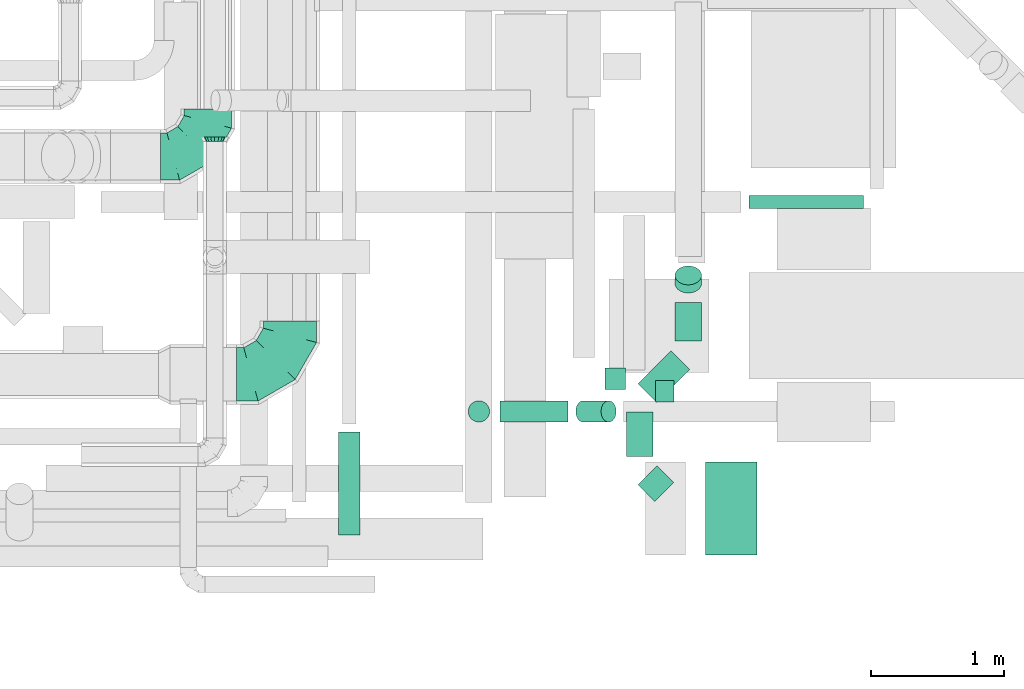
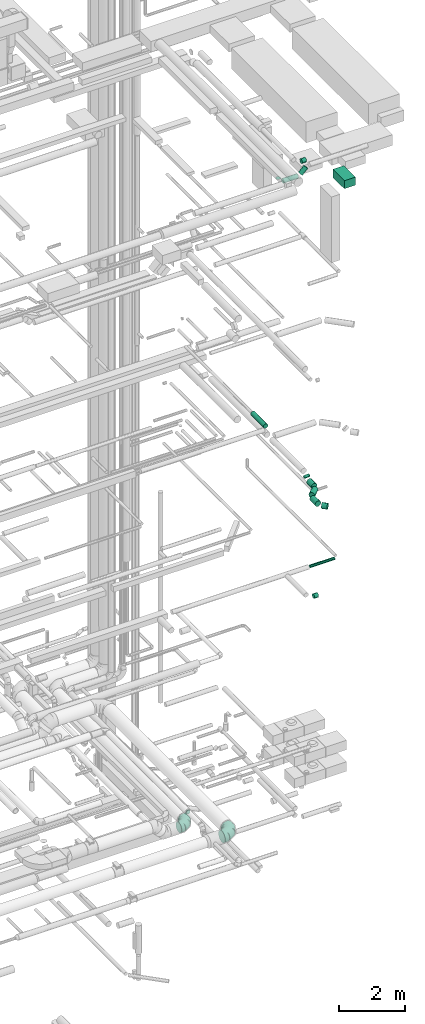
# One storey, part 212 of 337: 13 flow segments, 3 flow fittings.
"""IFC2X3 building model written with IfcOpenShell, lengths in millimetres."""

from ifc_helpers import new_model, entity, si_unit, converted_unit, derived_unit, direction, frame, origin, origin_2d_with_axis, place, context, subcontext, project, spatial, rectangle, circle, extrude, faceted_brep, source, transform, mapped, material, type_object, type_shapes, element, save


model = new_model("IFC2X3")

# Units and contexts
model_context = context("Model", 3, precision=0.01, world=origin(), true_north=direction((6.12303176911189e-17, 1.0)))
body_context = subcontext(model_context, "Body", "Model", "MODEL_VIEW")
ifc_project = project(units=[si_unit("LENGTHUNIT", "METRE", prefix="MILLI"), si_unit("AREAUNIT", "SQUARE_METRE"), si_unit("VOLUMEUNIT", "CUBIC_METRE"), converted_unit("PLANEANGLEUNIT", "DEGREE", entity("IfcRatioMeasure", 0.0174532925199433), si_unit("PLANEANGLEUNIT", "RADIAN"), dimensions=[0, 0, 0, 0, 0, 0, 0]), si_unit("MASSUNIT", "GRAM", prefix="KILO"), derived_unit("MASSDENSITYUNIT", [(si_unit("MASSUNIT", "GRAM", prefix="KILO"), 1), (si_unit("LENGTHUNIT", "METRE"), -3)]), derived_unit("MOMENTOFINERTIAUNIT", [(si_unit("LENGTHUNIT", "METRE"), 4)]), si_unit("TIMEUNIT", "SECOND"), si_unit("FREQUENCYUNIT", "HERTZ"), si_unit("THERMODYNAMICTEMPERATUREUNIT", "DEGREE_CELSIUS"), derived_unit("THERMALTRANSMITTANCEUNIT", [(si_unit("MASSUNIT", "GRAM", prefix="KILO"), 1), (si_unit("THERMODYNAMICTEMPERATUREUNIT", "KELVIN"), -1), (si_unit("TIMEUNIT", "SECOND"), -3)]), derived_unit("VOLUMETRICFLOWRATEUNIT", [(si_unit("LENGTHUNIT", "METRE"), 3), (si_unit("TIMEUNIT", "SECOND"), -1)]), derived_unit("MASSFLOWRATEUNIT", [(si_unit("MASSUNIT", "GRAM", prefix="KILO"), 1), (si_unit("TIMEUNIT", "SECOND"), -1)]), derived_unit("ROTATIONALFREQUENCYUNIT", [(si_unit("TIMEUNIT", "SECOND"), -1)]), si_unit("ELECTRICCURRENTUNIT", "AMPERE"), si_unit("ELECTRICVOLTAGEUNIT", "VOLT"), si_unit("POWERUNIT", "WATT"), si_unit("FORCEUNIT", "NEWTON", prefix="KILO"), si_unit("ILLUMINANCEUNIT", "LUX"), si_unit("LUMINOUSFLUXUNIT", "LUMEN"), si_unit("LUMINOUSINTENSITYUNIT", "CANDELA"), derived_unit("USERDEFINED", [(si_unit("MASSUNIT", "GRAM", prefix="KILO"), -1), (si_unit("LENGTHUNIT", "METRE"), -2), (si_unit("TIMEUNIT", "SECOND"), 3), (si_unit("LUMINOUSFLUXUNIT", "LUMEN"), 1)]), derived_unit("LINEARVELOCITYUNIT", [(si_unit("LENGTHUNIT", "METRE"), 1), (si_unit("TIMEUNIT", "SECOND"), -1)]), si_unit("PRESSUREUNIT", "PASCAL"), derived_unit("USERDEFINED", [(si_unit("LENGTHUNIT", "METRE"), -2), (si_unit("MASSUNIT", "GRAM", prefix="KILO"), 1), (si_unit("TIMEUNIT", "SECOND"), -2)]), derived_unit("LINEARFORCEUNIT", [(si_unit("MASSUNIT", "GRAM", prefix="KILO"), 1), (si_unit("LENGTHUNIT", "METRE"), 1), (si_unit("TIMEUNIT", "SECOND"), -2), (si_unit("LENGTHUNIT", "METRE"), -1)]), derived_unit("PLANARFORCEUNIT", [(si_unit("MASSUNIT", "GRAM", prefix="KILO"), 1), (si_unit("LENGTHUNIT", "METRE"), 1), (si_unit("TIMEUNIT", "SECOND"), -2), (si_unit("LENGTHUNIT", "METRE"), -2)])], contexts=[model_context])

# Site, building, storey
site_placement = place(None, origin())
site = spatial("IfcSite", under=ifc_project, at=site_placement, CompositionType="ELEMENT")
building_placement = place(site_placement, origin())
building = spatial("IfcBuilding", under=site, at=building_placement, CompositionType="ELEMENT")
storey_placement = place(building_placement, origin())
storey = spatial("IfcBuildingStorey", under=building, at=storey_placement, CompositionType="ELEMENT", Elevation=0.0)

# Flow segments
duct_segment_type_1 = type_object("IfcDuctSegmentType", PredefinedType="NOTDEFINED")
flow_segment_1_placement = place(storey_placement, frame((69418.15, 473.12, 27135.0)))
element("IfcFlowSegment", 1, at=flow_segment_1_placement, inside=storey, type_object=duct_segment_type_1, context=body_context, shape_type="SweptSolid", body=[
    extrude(rectangle(XDim=385.000000000034, YDim=700.0, at=origin_2d_with_axis()), frame((192.5, 350.0, 0.0), z_axis=(0.0, 0.0, 1.0), x_axis=(-1.0, 0.0, 0.0)), (0.0, 0.0, 1.0), 300.000000000001),
])
duct_segment_type_2 = type_object("IfcDuctSegmentType", PredefinedType="NOTDEFINED")
flow_segment_2_placement = place(storey_placement, frame((69741.92, 3071.28, 11348.4)))
element("IfcFlowSegment", 2, at=flow_segment_2_placement, inside=storey, type_object=duct_segment_type_2, context=body_context, shape_type="SweptSolid", body=[
    extrude(circle(Radius=50.0, at=origin_2d_with_axis()), frame((0.0, 51.6, 51.6), z_axis=(1.0, 0.0, 0.0), x_axis=(0.0, 1.0, 0.0)), (0.0, 0.0, 1.0), 859.999999999995),
])
flow_segment_3_placement = place(storey_placement, frame((69042.0, 1621.28, 11318.4)))
element("IfcFlowSegment", 3, at=flow_segment_3_placement, inside=storey, type_object=duct_segment_type_2, context=body_context, shape_type="SweptSolid", body=[
    extrude(circle(Radius=80.0, at=origin_2d_with_axis()), frame((0.0, 81.6, 81.6), z_axis=(1.0, 0.0, 0.0), x_axis=(0.0, 1.0, 0.0)), (0.0, 0.0, 1.0), 139.999999999986),
])
flow_segment_4_placement = place(storey_placement, frame((69185.94, 2438.64, 15158.27)))
element("IfcFlowSegment", 4, at=flow_segment_4_placement, inside=storey, type_object=duct_segment_type_2, context=body_context, shape_type="SweptSolid", body=[
    extrude(circle(Radius=100.0, at=origin_2d_with_axis()), frame((101.6, 72.31, 72.31), z_axis=(0.0, 0.707106781186546, 0.707106781186549), x_axis=(-1.0, 0.0, 0.0)), (0.0, 0.0, 1.0), 86.0445891531768),
])
flow_segment_5_placement = place(storey_placement, frame((69185.94, 2078.1, 15070.4)))
element("IfcFlowSegment", 5, at=flow_segment_5_placement, inside=storey, type_object=duct_segment_type_2, context=body_context, shape_type="SweptSolid", body=[
    extrude(circle(Radius=100.0, at=origin_2d_with_axis()), frame((101.6, 0.0, 101.6), z_axis=(0.0, 1.0, 0.0), x_axis=(-1.0, 0.0, 0.0)), (0.0, 0.0, 1.0), 291.425357525385),
])
flow_segment_6_placement = place(storey_placement, frame((68909.09, 1616.82, 15070.4)))
element("IfcFlowSegment", 6, at=flow_segment_6_placement, inside=storey, type_object=duct_segment_type_2, context=body_context, shape_type="SweptSolid", body=[
    extrude(circle(Radius=100.0, at=origin_2d_with_axis()), frame((72.31, 72.31, 101.6), z_axis=(0.707106781186577, 0.707106781186519, 0.0), x_axis=(-0.707106781186519, 0.707106781186577, 0.0)), (0.0, 0.0, 1.0), 350.102274594533),
])
flow_segment_7_placement = place(storey_placement, frame((68821.22, 1214.63, 15070.4)))
element("IfcFlowSegment", 7, at=flow_segment_7_placement, inside=storey, type_object=duct_segment_type_2, context=body_context, shape_type="SweptSolid", body=[
    extrude(circle(Radius=100.0, at=origin_2d_with_axis()), frame((101.6, 0.0, 101.6), z_axis=(0.0, 1.0, 0.0), x_axis=(-1.0, 0.0, 0.0)), (0.0, 0.0, 1.0), 333.068919247703),
])
flow_segment_8_placement = place(storey_placement, frame((68908.79, 874.86, 15070.4)))
element("IfcFlowSegment", 8, at=flow_segment_8_placement, inside=storey, type_object=duct_segment_type_2, context=body_context, shape_type="SweptSolid", body=[
    extrude(circle(Radius=100.0, at=origin_2d_with_axis()), frame((197.88, 72.0, 101.6), z_axis=(-0.704072207353623, 0.710128387569598, 0.0), x_axis=(-0.710128387569598, -0.704072207353623, 0.0)), (0.0, 0.0, 1.0), 177.920841126035),
])
flow_segment_9_placement = place(storey_placement, frame((66662.51, 623.31, 19093.4)))
element("IfcFlowSegment", 9, at=flow_segment_9_placement, inside=storey, type_object=duct_segment_type_2, context=body_context, shape_type="SweptSolid", body=[
    extrude(circle(Radius=80.0, at=origin_2d_with_axis()), frame((81.6, 0.0, 81.6), z_axis=(0.0, 1.0, 0.0), x_axis=(1.0, 0.0, 0.0)), (0.0, 0.0, 1.0), 775.000000000049),
])
flow_segment_10_placement = place(storey_placement, frame((68663.02, 1715.81, 27543.4)))
element("IfcFlowSegment", 10, at=flow_segment_10_placement, inside=storey, type_object=duct_segment_type_2, context=body_context, shape_type="SweptSolid", body=[
    extrude(circle(Radius=80.0, at=origin_2d_with_axis()), frame((0.0, 81.6, 81.6), z_axis=(1.0, 0.0, 0.0), x_axis=(0.0, -1.0, 0.0)), (0.0, 0.0, 1.0), 152.499999999983),
])
flow_segment_11_placement = place(storey_placement, frame((68442.02, 1469.8, 27305.29)))
element("IfcFlowSegment", 11, at=flow_segment_11_placement, inside=storey, type_object=duct_segment_type_2, context=body_context, shape_type="SweptSolid", body=[
    extrude(circle(Radius=80.0, at=origin_2d_with_axis()), frame((58.16, 81.6, 58.16), z_axis=(0.707106781186555, 0.0, 0.707106781186541), x_axis=(0.0, 1.0, 0.0)), (0.0, 0.0, 1.0), 268.248557872836),
])
flow_segment_12_placement = place(storey_placement, frame((67876.73, 1469.8, 27235.0)))
element("IfcFlowSegment", 12, at=flow_segment_12_placement, inside=storey, type_object=duct_segment_type_2, context=body_context, shape_type="SweptSolid", body=[
    extrude(circle(Radius=80.0, at=origin_2d_with_axis()), frame((0.0, 81.6, 81.6), z_axis=(1.0, 0.0, 0.0), x_axis=(0.0, 1.0, 0.0)), (0.0, 0.0, 1.0), 510.319625684626),
])
flow_segment_13_placement = place(storey_placement, frame((67635.13, 1469.8, 27476.59)))
element("IfcFlowSegment", 13, at=flow_segment_13_placement, inside=storey, type_object=duct_segment_type_2, context=body_context, shape_type="SweptSolid", body=[
    extrude(circle(Radius=80.0, at=origin_2d_with_axis()), frame((81.6, 81.6, 0.0), z_axis=(0.0, 0.0, 1.0), x_axis=(0.0, -1.0, 0.0)), (0.0, 0.0, 1.0), 3.40620433568134),
])

# Flow fittings
ifc_material = material()
duct_fitting_type_1 = type_object("IfcDuctFittingType", PredefinedType="NOTDEFINED", material=ifc_material)
shared_shape_1 = source(origin(), body_context, "Body", "Brep", [
    faceted_brep([(-400.0, 0.0, -200.0), (-400.0, -44.5, -194.99), (-400.0, -86.78, -180.19), (-400.0, -124.7, -156.37), (-400.0, -156.37, -124.7), (-400.0, -180.19, -86.78), (-400.0, -194.99, -44.5), (-400.0, -200.0, 0.0), (-400.0, -194.99, 44.5), (-400.0, -180.19, 86.78), (-400.0, -156.37, 124.7), (-400.0, -124.7, 156.37), (-400.0, -86.78, 180.19), (-400.0, -44.5, 194.99), (-400.0, 0.0, 200.0), (-400.0, 44.5, 194.99), (-400.0, 86.78, 180.19), (-400.0, 124.7, 156.37), (-400.0, 156.37, 124.7), (-400.0, 180.19, 86.78), (-400.0, 194.99, 44.5), (-400.0, 200.0, 0.0), (-400.0, 194.99, -44.5), (-400.0, 180.19, -86.78), (-400.0, 156.37, -124.7), (-400.0, 124.7, -156.37), (-400.0, 86.78, -180.19), (-400.0, 44.5, -194.99), (-292.82, 0.0, 200.0), (-304.75, 44.5, 194.99), (-316.07, 86.78, 180.19), (-326.23, 124.7, 156.37), (-334.72, 156.37, 124.7), (-341.1, 180.19, 86.78), (-345.07, 194.99, 44.5), (-346.41, 200.0, 0.0), (-345.07, 194.99, -44.5), (-341.1, 180.19, -86.78), (-334.72, 156.37, -124.7), (-326.23, 124.7, -156.37), (-316.07, 86.78, -180.19), (-304.75, 44.5, -194.99), (-292.82, 0.0, -200.0), (-280.9, -44.5, -194.99), (-269.57, -86.78, -180.19), (-259.41, -124.7, -156.37), (-250.92, -156.37, -124.7), (-244.54, -180.19, -86.78), (-240.57, -194.99, -44.5), (-239.23, -200.0, 0.0), (-240.57, -194.99, 44.5), (-244.54, -180.19, 86.78), (-250.92, -156.37, 124.7), (-259.41, -124.7, 156.37), (-269.57, -86.78, 180.19), (-280.9, -44.5, 194.99), (-107.18, 107.18, 200.0), (-139.76, 139.76, 194.99), (-170.7, 170.7, 180.19), (-198.46, 198.46, 156.37), (-221.65, 221.65, 124.7), (-239.09, 239.09, 86.78), (-249.92, 249.92, 44.5), (-253.59, 253.59, 0.0), (-249.92, 249.92, -44.5), (-239.09, 239.09, -86.78), (-221.65, 221.65, -124.7), (-198.46, 198.46, -156.37), (-170.7, 170.7, -180.19), (-139.76, 139.76, -194.99), (-107.18, 107.18, -200.0), (-74.6, 74.6, -194.99), (-43.65, 43.65, -180.19), (-15.89, 15.89, -156.37), (7.29, -7.29, -124.7), (24.73, -24.73, -86.78), (35.56, -35.56, -44.5), (39.23, -39.23, 0.0), (35.56, -35.56, 44.5), (24.73, -24.73, 86.78), (7.29, -7.29, 124.7), (-15.89, 15.89, 156.37), (-43.65, 43.65, 180.19), (-74.6, 74.6, 194.99), (0.0, 292.82, 200.0), (-44.5, 304.75, 194.99), (-86.78, 316.07, 180.19), (-124.7, 326.23, 156.37), (-156.37, 334.72, 124.7), (-180.19, 341.1, 86.78), (-194.99, 345.07, 44.5), (-200.0, 346.41, 0.0), (-194.99, 345.07, -44.5), (-180.19, 341.1, -86.78), (-156.37, 334.72, -124.7), (-124.7, 326.23, -156.37), (-86.78, 316.07, -180.19), (-44.5, 304.75, -194.99), (0.0, 292.82, -200.0), (44.5, 280.9, -194.99), (86.78, 269.57, -180.19), (124.7, 259.41, -156.37), (156.37, 250.92, -124.7), (180.19, 244.54, -86.78), (194.99, 240.57, -44.5), (200.0, 239.23, 0.0), (194.99, 240.57, 44.5), (180.19, 244.54, 86.78), (156.37, 250.92, 124.7), (124.7, 259.41, 156.37), (86.78, 269.57, 180.19), (44.5, 280.9, 194.99), (-44.5, 400.0, -194.99), (-86.78, 400.0, -180.19), (-124.7, 400.0, -156.37), (-156.37, 400.0, -124.7), (-180.19, 400.0, -86.78), (-194.99, 400.0, -44.5), (-200.0, 400.0, 0.0), (-194.99, 400.0, 44.5), (-180.19, 400.0, 86.78), (-156.37, 400.0, 124.7), (-124.7, 400.0, 156.37), (-86.78, 400.0, 180.19), (-44.5, 400.0, 194.99), (0.0, 400.0, 200.0), (44.5, 400.0, 194.99), (86.78, 400.0, 180.19), (124.7, 400.0, 156.37), (156.37, 400.0, 124.7), (180.19, 400.0, 86.78), (194.99, 400.0, 44.5), (200.0, 400.0, 0.0), (194.99, 400.0, -44.5), (180.19, 400.0, -86.78), (156.37, 400.0, -124.7), (124.7, 400.0, -156.37), (86.78, 400.0, -180.19), (44.5, 400.0, -194.99), (0.0, 400.0, -200.0)], [[[0, 1, 2, 3, 4, 5, 6, 7, 8, 9, 10, 11, 12, 13, 14, 15, 16, 17, 18, 19, 20, 21, 22, 23, 24, 25, 26, 27]], [[28, 29, 15, 14]], [[30, 31, 17, 16]], [[29, 30, 16, 15]], [[31, 32, 18, 17]], [[32, 33, 19, 18]], [[34, 35, 21, 20]], [[33, 34, 20, 19]], [[35, 36, 22, 21]], [[37, 38, 24, 23]], [[36, 37, 23, 22]], [[38, 39, 25, 24]], [[39, 40, 26, 25]], [[41, 42, 0, 27]], [[40, 41, 27, 26]], [[1, 0, 42, 43]], [[43, 44, 2, 1]], [[45, 3, 2, 44]], [[45, 46, 4, 3]], [[5, 4, 46, 47]], [[47, 48, 6, 5]], [[49, 7, 6, 48]], [[7, 49, 50, 8]], [[8, 50, 51, 9]], [[9, 51, 52, 10]], [[52, 53, 11, 10]], [[11, 53, 54, 12]], [[12, 54, 55, 13]], [[13, 55, 28, 14]], [[56, 57, 29, 28]], [[58, 59, 31, 30]], [[57, 58, 30, 29]], [[59, 60, 32, 31]], [[60, 61, 33, 32]], [[62, 63, 35, 34]], [[61, 62, 34, 33]], [[63, 64, 36, 35]], [[65, 66, 38, 37]], [[64, 65, 37, 36]], [[66, 67, 39, 38]], [[67, 68, 40, 39]], [[69, 70, 42, 41]], [[68, 69, 41, 40]], [[43, 42, 70, 71]], [[71, 72, 44, 43]], [[73, 45, 44, 72]], [[73, 74, 46, 45]], [[47, 46, 74, 75]], [[75, 76, 48, 47]], [[77, 49, 48, 76]], [[50, 49, 77, 78]], [[51, 50, 78, 79]], [[52, 51, 79, 80]], [[80, 81, 53, 52]], [[54, 53, 81, 82]], [[55, 54, 82, 83]], [[28, 55, 83, 56]], [[84, 85, 57, 56]], [[86, 87, 59, 58]], [[85, 86, 58, 57]], [[87, 88, 60, 59]], [[88, 89, 61, 60]], [[90, 91, 63, 62]], [[89, 90, 62, 61]], [[91, 92, 64, 63]], [[93, 94, 66, 65]], [[92, 93, 65, 64]], [[94, 95, 67, 66]], [[95, 96, 68, 67]], [[97, 98, 70, 69]], [[96, 97, 69, 68]], [[71, 70, 98, 99]], [[99, 100, 72, 71]], [[101, 73, 72, 100]], [[101, 102, 74, 73]], [[75, 74, 102, 103]], [[103, 104, 76, 75]], [[105, 77, 76, 104]], [[78, 77, 105, 106]], [[79, 78, 106, 107]], [[80, 79, 107, 108]], [[108, 109, 81, 80]], [[82, 81, 109, 110]], [[83, 82, 110, 111]], [[56, 83, 111, 84]], [[112, 113, 114, 115, 116, 117, 118, 119, 120, 121, 122, 123, 124, 125, 126, 127, 128, 129, 130, 131, 132, 133, 134, 135, 136, 137, 138, 139]], [[85, 84, 125, 124]], [[86, 85, 124, 123]], [[87, 86, 123, 122]], [[122, 121, 88, 87]], [[89, 88, 121, 120]], [[90, 89, 120, 119]], [[91, 90, 119, 118]], [[91, 118, 117, 92]], [[92, 117, 116, 93]], [[93, 116, 115, 94]], [[115, 114, 95, 94]], [[95, 114, 113, 96]], [[96, 113, 112, 97]], [[97, 112, 139, 98]], [[98, 139, 138, 99]], [[99, 138, 137, 100]], [[100, 137, 136, 101]], [[136, 135, 102, 101]], [[102, 135, 134, 103]], [[103, 134, 133, 104]], [[104, 133, 132, 105]], [[106, 105, 132, 131]], [[107, 106, 131, 130]], [[108, 107, 130, 129]], [[129, 128, 109, 108]], [[110, 109, 128, 127]], [[111, 110, 127, 126]], [[84, 111, 126, 125]]]),
])
type_shapes(duct_fitting_type_1, [shared_shape_1])
flow_fitting_1_placement = place(storey_placement, frame((66298.97, 1829.37, 3500.0)))
element("IfcFlowFitting", 14, at=flow_fitting_1_placement, inside=storey, type_object=duct_fitting_type_1, material=ifc_material, context=body_context, shape_type="MappedRepresentation", body=[
    mapped(shared_shape_1, transform((0.0, 0.0, 0.0), scale=1.0)),
])
duct_fitting_type_2 = type_object("IfcDuctFittingType", PredefinedType="NOTDEFINED", material=ifc_material)
shared_shape_2 = source(origin(), body_context, "Body", "Brep", [
    faceted_brep([(35.0, 0.0, -80.0), (35.0, 12.81, -77.45), (35.0, 30.61, -73.91), (35.0, 43.59, -65.24), (35.0, 56.57, -56.57), (35.0, 65.24, -43.59), (35.0, 73.91, -30.61), (35.0, 76.96, -15.31), (35.0, 80.0, 0.0), (35.0, 77.45, 12.81), (35.0, 73.91, 30.61), (35.0, 65.24, 43.59), (35.0, 56.57, 56.57), (35.0, 43.59, 65.24), (35.0, 30.61, 73.91), (35.0, 15.31, 76.96), (35.0, 0.0, 80.0), (35.0, -12.81, 77.45), (35.0, -30.61, 73.91), (35.0, -43.59, 65.24), (35.0, -56.57, 56.57), (35.0, -65.24, 43.59), (35.0, -73.91, 30.61), (35.0, -76.96, 15.31), (35.0, -80.0, 0.0), (35.0, -77.45, -12.81), (35.0, -73.91, -30.61), (35.0, -65.24, -43.59), (35.0, -56.57, -56.57), (35.0, -43.59, -65.24), (35.0, -30.61, -73.91), (35.0, -15.31, -76.96), (0.0, -23.92, -57.74), (0.0, -34.06, -50.97), (0.0, -44.19, -44.19), (0.0, -50.97, -34.06), (0.0, -57.74, -23.92), (0.0, -60.12, -11.96), (0.0, -62.5, 0.0), (0.0, -60.12, 11.96), (0.0, -57.74, 23.92), (0.0, -50.97, 34.06), (0.0, -44.19, 44.19), (0.0, -34.06, 50.97), (0.0, -23.92, 57.74), (0.0, -11.96, 60.12), (0.0, 0.0, 62.5), (0.0, 11.96, 60.12), (0.0, 23.92, 57.74), (0.0, 34.06, 50.97), (0.0, 44.19, 44.19), (0.0, 50.97, 34.06), (0.0, 57.74, 23.92), (0.0, 60.12, 11.96), (0.0, 62.5, 0.0), (0.0, 60.12, -11.96), (0.0, 57.74, -23.92), (0.0, 50.97, -34.06), (0.0, 44.19, -44.19), (0.0, 34.06, -50.97), (0.0, 23.92, -57.74), (0.0, 11.96, -60.12), (0.0, 0.0, -62.5), (0.0, -11.96, -60.12)], [[[0, 1, 2, 3, 4, 5, 6, 7, 8, 9, 10, 11, 12, 13, 14, 15, 16, 17, 18, 19, 20, 21, 22, 23, 24, 25, 26, 27, 28, 29, 30, 31]], [[32, 33, 34, 35, 36, 37, 38, 39, 40, 41, 42, 43, 44, 45, 46, 47, 48, 49, 50, 51, 52, 53, 54, 55, 56, 57, 58, 59, 60, 61, 62, 63]], [[10, 9, 8, 54, 53, 52]], [[11, 10, 52, 51, 50, 12]], [[48, 14, 13, 12, 50, 49]], [[46, 16, 15, 14, 48, 47]], [[18, 17, 16, 46, 45, 44]], [[19, 18, 44, 43, 42, 20]], [[40, 22, 21, 20, 42, 41]], [[38, 24, 23, 22, 40, 39]], [[26, 25, 24, 38, 37, 36]], [[27, 26, 36, 35, 34, 28]], [[32, 30, 29, 28, 34, 33]], [[62, 0, 31, 30, 32, 63]], [[2, 1, 0, 62, 61, 60]], [[3, 2, 60, 59, 58, 4]], [[56, 6, 5, 4, 58, 57]], [[54, 8, 7, 6, 56, 55]]]),
])
type_shapes(duct_fitting_type_2, [shared_shape_2])
flow_fitting_2_placement = place(storey_placement, frame((65734.68, 3575.46, 3400.0), z_axis=(0.0, 0.0, 1.0), x_axis=(0.0, 1.0, 0.0)))
element("IfcFlowFitting", 15, at=flow_fitting_2_placement, inside=storey, type_object=duct_fitting_type_2, material=ifc_material, context=body_context, shape_type="MappedRepresentation", body=[
    mapped(shared_shape_2, transform((0.0, 0.0, 0.0), scale=1.0)),
])
duct_fitting_type_3 = type_object("IfcDuctFittingType", PredefinedType="NOTDEFINED", material=ifc_material)
shared_shape_3 = source(origin(), body_context, "Body", "Brep", [
    faceted_brep([(-355.0, 0.0, -177.5), (-355.0, -45.94, -171.45), (-355.0, -88.75, -153.72), (-355.0, -125.51, -125.51), (-355.0, -153.72, -88.75), (-355.0, -171.45, -45.94), (-355.0, -177.5, 0.0), (-355.0, -171.45, 45.94), (-355.0, -153.72, 88.75), (-355.0, -125.51, 125.51), (-355.0, -88.75, 153.72), (-355.0, -45.94, 171.45), (-355.0, 0.0, 177.5), (-355.0, 45.94, 171.45), (-355.0, 88.75, 153.72), (-355.0, 125.51, 125.51), (-355.0, 153.72, 88.75), (-355.0, 171.45, 45.94), (-355.0, 177.5, 0.0), (-355.0, 171.45, -45.94), (-355.0, 153.72, -88.75), (-355.0, 125.51, -125.51), (-355.0, 88.75, -153.72), (-355.0, 45.94, -171.45), (-272.19, 45.94, 171.45), (-283.66, 88.75, 153.72), (-259.88, 0.0, 177.5), (-293.51, 125.51, 125.51), (-305.82, 171.45, 45.94), (-307.44, 177.5, 0.0), (-301.07, 153.72, 88.75), (-301.07, 153.72, -88.75), (-293.51, 125.51, -125.51), (-305.82, 171.45, -45.94), (-272.19, 45.94, -171.45), (-259.88, 0.0, -177.5), (-283.66, 88.75, -153.72), (-247.57, -45.94, -171.45), (-236.1, -88.75, -153.72), (-226.25, -125.51, -125.51), (-218.69, -153.72, -88.75), (-213.94, -171.45, -45.94), (-212.32, -177.5, 0.0), (-213.94, -171.45, 45.94), (-218.69, -153.72, 88.75), (-226.25, -125.51, 125.51), (-236.1, -88.75, 153.72), (-247.57, -45.94, 171.45), (-128.75, 128.75, 171.45), (-160.09, 160.09, 153.72), (-95.12, 95.12, 177.5), (-187.0, 187.0, 125.51), (-207.65, 207.65, 88.75), (-220.63, 220.63, 45.94), (-225.06, 225.06, 0.0), (-220.63, 220.63, -45.94), (-207.65, 207.65, -88.75), (-187.0, 187.0, -125.51), (-128.75, 128.75, -171.45), (-95.12, 95.12, -177.5), (-160.09, 160.09, -153.72), (-61.49, 61.49, -171.45), (-30.15, 30.15, -153.72), (-3.24, 3.24, -125.51), (17.41, -17.41, -88.75), (30.39, -30.39, -45.94), (34.82, -34.82, 0.0), (30.39, -30.39, 45.94), (17.41, -17.41, 88.75), (-3.24, 3.24, 125.51), (-30.15, 30.15, 153.72), (-61.49, 61.49, 171.45), (-45.94, 272.19, 171.45), (-88.75, 283.66, 153.72), (0.0, 259.88, 177.5), (-125.51, 293.51, 125.51), (-153.72, 301.07, 88.75), (-171.45, 305.82, 45.94), (-177.5, 307.44, 0.0), (-171.45, 305.82, -45.94), (-153.72, 301.07, -88.75), (-125.51, 293.51, -125.51), (-45.94, 272.19, -171.45), (0.0, 259.88, -177.5), (-88.75, 283.66, -153.72), (45.94, 247.57, -171.45), (88.75, 236.1, -153.72), (125.51, 226.25, -125.51), (153.72, 218.69, -88.75), (171.45, 213.94, -45.94), (177.5, 212.32, 0.0), (171.45, 213.94, 45.94), (153.72, 218.69, 88.75), (125.51, 226.25, 125.51), (88.75, 236.1, 153.72), (45.94, 247.57, 171.45), (-45.94, 355.0, -171.45), (-88.75, 355.0, -153.72), (-125.51, 355.0, -125.51), (-153.72, 355.0, -88.75), (-171.45, 355.0, -45.94), (-177.5, 355.0, 0.0), (-171.45, 355.0, 45.94), (-153.72, 355.0, 88.75), (-125.51, 355.0, 125.51), (-88.75, 355.0, 153.72), (-45.94, 355.0, 171.45), (0.0, 355.0, 177.5), (45.94, 355.0, 171.45), (88.75, 355.0, 153.72), (125.51, 355.0, 125.51), (153.72, 355.0, 88.75), (171.45, 355.0, 45.94), (177.5, 355.0, 0.0), (171.45, 355.0, -45.94), (153.72, 355.0, -88.75), (125.51, 355.0, -125.51), (88.75, 355.0, -153.72), (45.94, 355.0, -171.45), (0.0, 355.0, -177.5)], [[[0, 1, 2, 3, 4, 5, 6, 7, 8, 9, 10, 11, 12, 13, 14, 15, 16, 17, 18, 19, 20, 21, 22, 23]], [[24, 25, 14, 13]], [[26, 24, 13, 12]], [[14, 25, 27, 15]], [[28, 29, 18, 17]], [[30, 28, 17, 16]], [[15, 27, 30, 16]], [[20, 31, 32, 21]], [[33, 31, 20, 19]], [[18, 29, 33, 19]], [[34, 35, 0, 23]], [[36, 34, 23, 22]], [[32, 36, 22, 21]], [[1, 0, 35, 37]], [[2, 1, 37, 38]], [[38, 39, 3, 2]], [[5, 4, 40, 41]], [[6, 5, 41, 42]], [[39, 40, 4, 3]], [[6, 42, 43, 7]], [[7, 43, 44, 8]], [[8, 44, 45, 9]], [[9, 45, 46, 10]], [[10, 46, 47, 11]], [[26, 12, 11, 47]], [[48, 49, 25, 24]], [[50, 48, 24, 26]], [[27, 25, 49, 51]], [[52, 53, 28, 30]], [[51, 52, 30, 27]], [[29, 28, 53, 54]], [[55, 56, 31, 33]], [[54, 55, 33, 29]], [[32, 31, 56, 57]], [[58, 59, 35, 34]], [[60, 58, 34, 36]], [[57, 60, 36, 32]], [[37, 35, 59, 61]], [[38, 37, 61, 62]], [[39, 38, 62, 63]], [[41, 40, 64, 65]], [[42, 41, 65, 66]], [[63, 64, 40, 39]], [[43, 42, 66, 67]], [[44, 43, 67, 68]], [[68, 69, 45, 44]], [[46, 45, 69, 70]], [[47, 46, 70, 71]], [[26, 47, 71, 50]], [[72, 73, 49, 48]], [[74, 72, 48, 50]], [[51, 49, 73, 75]], [[76, 77, 53, 52]], [[75, 76, 52, 51]], [[54, 53, 77, 78]], [[79, 80, 56, 55]], [[78, 79, 55, 54]], [[57, 56, 80, 81]], [[82, 83, 59, 58]], [[84, 82, 58, 60]], [[81, 84, 60, 57]], [[61, 59, 83, 85]], [[62, 61, 85, 86]], [[63, 62, 86, 87]], [[65, 64, 88, 89]], [[66, 65, 89, 90]], [[87, 88, 64, 63]], [[67, 66, 90, 91]], [[68, 67, 91, 92]], [[92, 93, 69, 68]], [[70, 69, 93, 94]], [[71, 70, 94, 95]], [[50, 71, 95, 74]], [[96, 97, 98, 99, 100, 101, 102, 103, 104, 105, 106, 107, 108, 109, 110, 111, 112, 113, 114, 115, 116, 117, 118, 119]], [[72, 74, 107, 106]], [[73, 72, 106, 105]], [[75, 73, 105, 104]], [[77, 76, 103, 102]], [[78, 77, 102, 101]], [[104, 103, 76, 75]], [[78, 101, 100, 79]], [[79, 100, 99, 80]], [[98, 81, 80, 99]], [[84, 97, 96, 82]], [[82, 96, 119, 83]], [[97, 84, 81, 98]], [[83, 119, 118, 85]], [[85, 118, 117, 86]], [[116, 87, 86, 117]], [[88, 115, 114, 89]], [[89, 114, 113, 90]], [[115, 88, 87, 116]], [[91, 90, 113, 112]], [[92, 91, 112, 111]], [[111, 110, 93, 92]], [[95, 94, 109, 108]], [[74, 95, 108, 107]], [[110, 109, 94, 93]]]),
])
type_shapes(duct_fitting_type_3, [shared_shape_3])
flow_fitting_3_placement = place(storey_placement, frame((65683.23, 3464.15, 3050.0)))
element("IfcFlowFitting", 16, at=flow_fitting_3_placement, inside=storey, type_object=duct_fitting_type_3, material=ifc_material, context=body_context, shape_type="MappedRepresentation", body=[
    mapped(shared_shape_3, transform((0.0, 0.0, 0.0), scale=1.0)),
])

save(model, "model.ifc")
